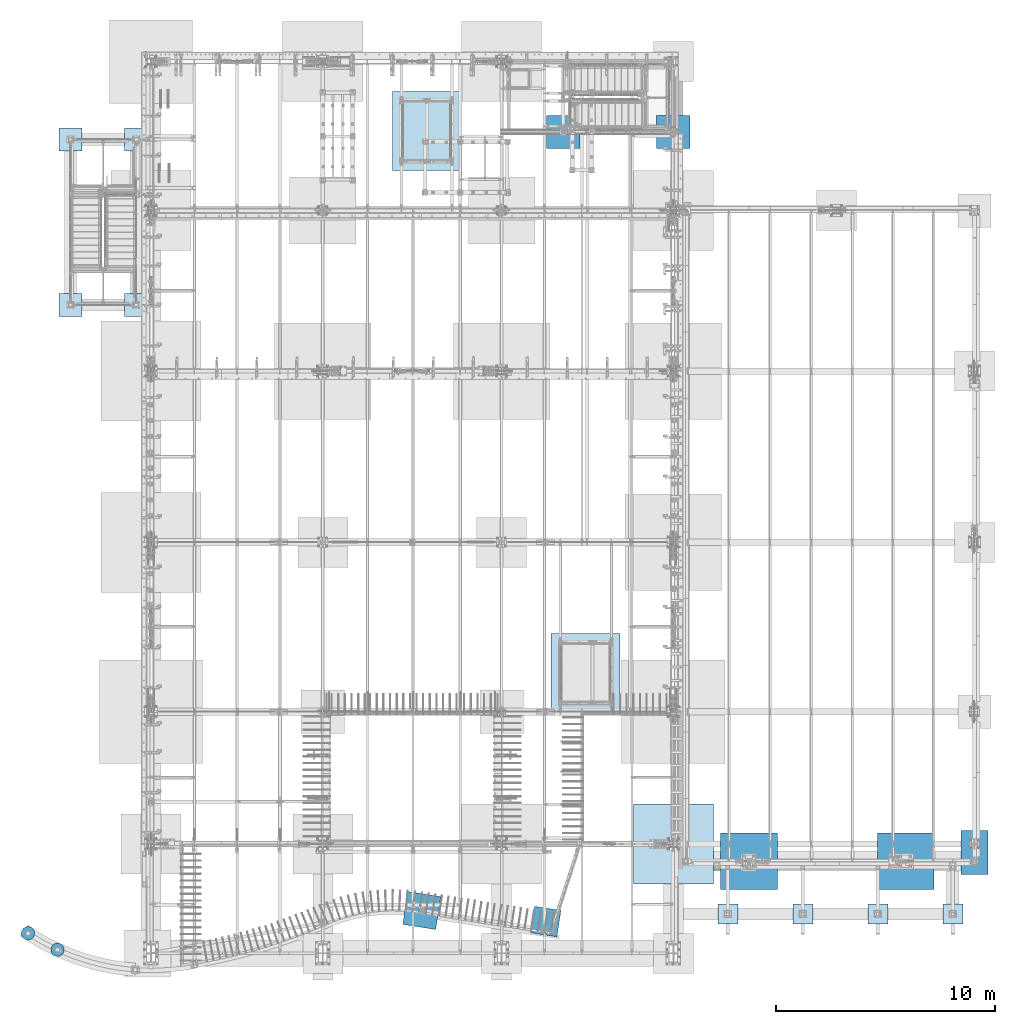
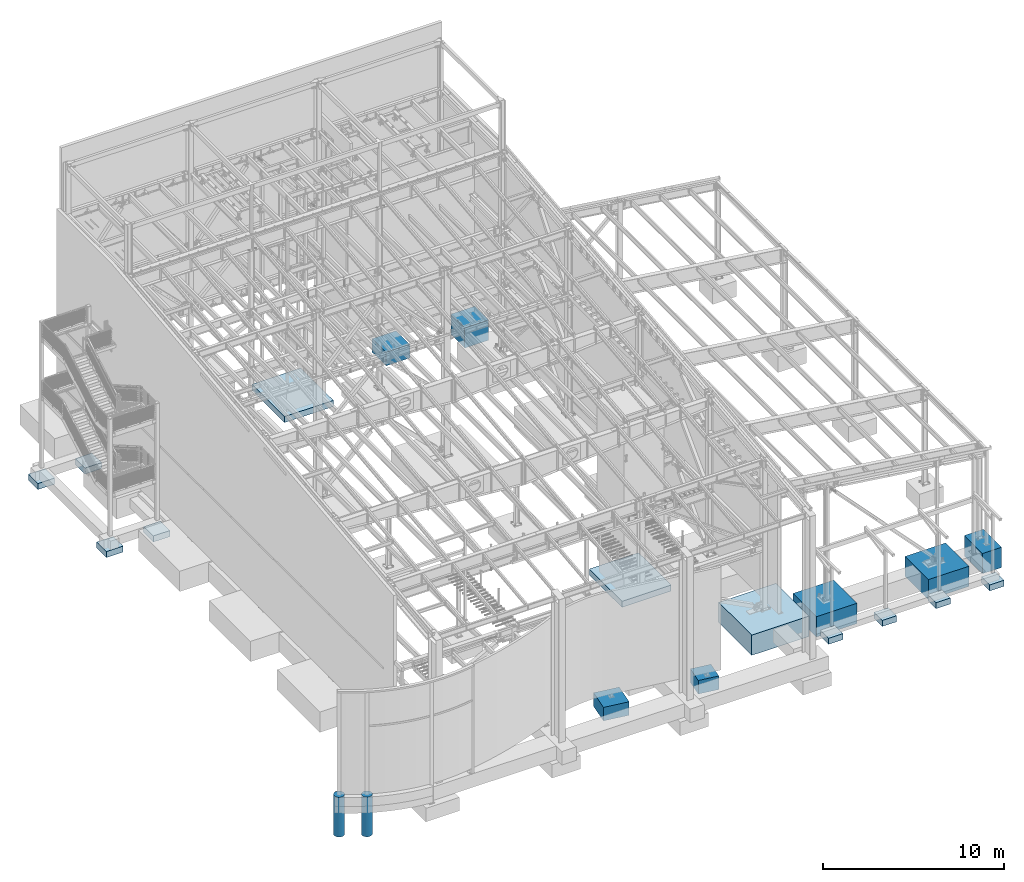
# One storey, part 350 of 1179: 20 footings, 20 elements without a shape of their own.
"""IFC2X3 building model written with IfcOpenShell, lengths in millimetres."""

from ifc_helpers import new_model, si_unit, frame, origin_with_axes, place, context, subcontext, project, spatial, faceted_brep, material, element, aggregate, save


model = new_model("IFC2X3")

# Units and contexts
model_context = context("Model", 3, precision=1e-05, world=origin_with_axes())
body_context = subcontext(model_context, "Body", "Model", "MODEL_VIEW")
ifc_project = project(units=[si_unit("LENGTHUNIT", "METRE", prefix="MILLI"), si_unit("AREAUNIT", "SQUARE_METRE"), si_unit("VOLUMEUNIT", "CUBIC_METRE"), si_unit("MASSUNIT", "GRAM", prefix="KILO"), si_unit("TIMEUNIT", "SECOND"), si_unit("PLANEANGLEUNIT", "RADIAN"), si_unit("SOLIDANGLEUNIT", "STERADIAN"), si_unit("THERMODYNAMICTEMPERATUREUNIT", "DEGREE_CELSIUS"), si_unit("LUMINOUSINTENSITYUNIT", "LUMEN")], contexts=[model_context])

# Site, building, storey
site_placement = place(None, origin_with_axes())
site = spatial("IfcSite", under=ifc_project, at=site_placement, CompositionType="ELEMENT")
building_placement = place(site_placement, origin_with_axes())
building = spatial("IfcBuilding", under=site, at=building_placement, Name="Undefined", CompositionType="ELEMENT")
storey_placement = place(building_placement, origin_with_axes())
storey = spatial("IfcBuildingStorey", under=building, at=storey_placement, Name="Undefined", CompositionType="ELEMENT", Elevation=0.0)

# Assembly, footing
assembly_1_placement = place(storey_placement, origin_with_axes())
assembly_1 = element("IfcElementAssembly", 1, at=assembly_1_placement, inside=storey, Name="PAD FOOTING", AssemblyPlace="NOTDEFINED", PredefinedType="REINFORCEMENT_UNIT")
ifc_material = material(Name="CONCRETE/3000")
footing_1_placement = place(assembly_1_placement, frame((-254.0, 37642.8, -1651.0), z_axis=(1.0, 0.0, 0.0), x_axis=(0.0, 0.0, 1.0)))
footing_1 = element("IfcFooting", 2, at=footing_1_placement, material=ifc_material, Name="PAD FOOTING", PredefinedType="NOTDEFINED", context=body_context, shape_type="Brep", body=[
    faceted_brep([(0.0, 533.400000000001, -533.4), (0.0, 533.400000000001, 533.4), (406.4, 533.400000000001, 533.4), (406.4, 533.400000000001, -533.4), (0.0, -533.400000000001, 533.4), (406.4, -533.400000000001, 533.4), (0.0, -533.400000000001, -533.4), (406.4, -533.400000000001, -533.4)], [[[0, 1, 2, 3]], [[1, 4, 5, 2]], [[4, 6, 7, 5]], [[6, 0, 3, 7]], [[5, 7, 3, 2]], [[6, 4, 1, 0]]]),
])
aggregate(assembly_1, [footing_1])

assembly_2_placement = place(storey_placement, origin_with_axes())
assembly_2 = element("IfcElementAssembly", 3, at=assembly_2_placement, inside=storey, Name="PAD FOOTING", AssemblyPlace="NOTDEFINED", PredefinedType="REINFORCEMENT_UNIT")
footing_2_placement = place(assembly_2_placement, frame((-254.0, 30073.6, -1651.0), z_axis=(1.0, 0.0, 0.0), x_axis=(0.0, 0.0, 1.0)))
footing_2 = element("IfcFooting", 4, at=footing_2_placement, material=ifc_material, Name="PAD FOOTING", PredefinedType="NOTDEFINED", context=body_context, shape_type="Brep", body=[
    faceted_brep([(0.0, 533.400000000001, -533.4), (0.0, 533.400000000001, 533.4), (406.4, 533.400000000001, 533.4), (406.4, 533.400000000001, -533.4), (0.0, -533.400000000001, 533.4), (406.4, -533.400000000001, 533.4), (0.0, -533.400000000001, -533.4), (406.4, -533.400000000001, -533.4)], [[[0, 1, 2, 3]], [[1, 4, 5, 2]], [[4, 6, 7, 5]], [[6, 0, 3, 7]], [[5, 7, 3, 2]], [[6, 4, 1, 0]]]),
])
aggregate(assembly_2, [footing_2])

assembly_3_placement = place(storey_placement, origin_with_axes())
assembly_3 = element("IfcElementAssembly", 5, at=assembly_3_placement, inside=storey, Name="PAD FOOTING", AssemblyPlace="NOTDEFINED", PredefinedType="REINFORCEMENT_UNIT")
footing_3_placement = place(assembly_3_placement, frame((-3251.2, 30073.6, -1651.0), z_axis=(1.0, 0.0, 0.0), x_axis=(0.0, 0.0, 1.0)))
footing_3 = element("IfcFooting", 6, at=footing_3_placement, material=ifc_material, Name="PAD FOOTING", PredefinedType="NOTDEFINED", context=body_context, shape_type="Brep", body=[
    faceted_brep([(0.0, 533.400000000001, -533.4), (0.0, 533.400000000001, 533.4), (406.4, 533.400000000001, 533.4), (406.4, 533.400000000001, -533.4), (0.0, -533.400000000001, 533.4), (406.4, -533.400000000001, 533.4), (0.0, -533.400000000001, -533.4), (406.4, -533.400000000001, -533.4)], [[[0, 1, 2, 3]], [[1, 4, 5, 2]], [[4, 6, 7, 5]], [[6, 0, 3, 7]], [[5, 7, 3, 2]], [[6, 4, 1, 0]]]),
])
aggregate(assembly_3, [footing_3])

assembly_4_placement = place(storey_placement, origin_with_axes())
assembly_4 = element("IfcElementAssembly", 7, at=assembly_4_placement, inside=storey, Name="PAD FOOTING", AssemblyPlace="NOTDEFINED", PredefinedType="REINFORCEMENT_UNIT")
footing_4_placement = place(assembly_4_placement, frame((-3251.2, 37642.8, -1651.0), z_axis=(1.0, 0.0, 0.0), x_axis=(0.0, 0.0, 1.0)))
footing_4 = element("IfcFooting", 8, at=footing_4_placement, material=ifc_material, Name="PAD FOOTING", PredefinedType="NOTDEFINED", context=body_context, shape_type="Brep", body=[
    faceted_brep([(0.0, 533.400000000001, -533.4), (0.0, 533.400000000001, 533.4), (406.4, 533.400000000001, 533.4), (406.4, 533.400000000001, -533.4), (0.0, -533.400000000001, 533.4), (406.4, -533.400000000001, 533.4), (0.0, -533.400000000001, -533.4), (406.4, -533.400000000001, -533.4)], [[[0, 1, 2, 3]], [[1, 4, 5, 2]], [[4, 6, 7, 5]], [[6, 0, 3, 7]], [[5, 7, 3, 2]], [[6, 4, 1, 0]]]),
])
aggregate(assembly_4, [footing_4])

assembly_5_placement = place(storey_placement, origin_with_axes())
assembly_5 = element("IfcElementAssembly", 9, at=assembly_5_placement, inside=storey, Name="PAD FOOTING", AssemblyPlace="NOTDEFINED", PredefinedType="REINFORCEMENT_UNIT")
footing_5_placement = place(assembly_5_placement, frame((18475.5679045266, 1891.26503542878, -1346.2), z_axis=(0.988012031439376, -0.154376895068652, 0.0), x_axis=(0.0, 0.0, 1.0)))
footing_5 = element("IfcFooting", 10, at=footing_5_placement, material=ifc_material, Name="PAD FOOTING", PredefinedType="NOTDEFINED", context=body_context, shape_type="Brep", body=[
    faceted_brep([(0.0, 609.600000000165, -609.600000001028), (0.0, 609.59999999992, 609.600000000977), (914.4, 609.59999999992, 609.600000000977), (914.4, 609.600000000165, -609.600000001028), (0.0, -609.600000000166, 609.600000001032), (914.4, -609.600000000166, 609.600000001032), (0.0, -609.599999999921, -609.600000000974), (914.4, -609.599999999921, -609.600000000974)], [[[0, 1, 2, 3]], [[1, 4, 5, 2]], [[4, 6, 7, 5]], [[6, 0, 3, 7]], [[5, 7, 3, 2]], [[6, 4, 1, 0]]]),
])
aggregate(assembly_5, [footing_5])

assembly_6_placement = place(storey_placement, origin_with_axes())
assembly_6 = element("IfcElementAssembly", 11, at=assembly_6_placement, inside=storey, Name="PAD FOOTING", AssemblyPlace="NOTDEFINED", PredefinedType="REINFORCEMENT_UNIT")
footing_6_placement = place(assembly_6_placement, frame((12807.7286542525, 2395.53749981878, -1346.2), z_axis=(0.988012031439376, -0.154376895068652, 0.0), x_axis=(0.0, 0.0, 1.0)))
footing_6 = element("IfcFooting", 12, at=footing_6_placement, material=ifc_material, Name="PAD FOOTING", PredefinedType="NOTDEFINED", context=body_context, shape_type="Brep", body=[
    faceted_brep([(0.0, 761.999999999822, -761.999999999945), (0.0, 761.999999999945, 761.99999999982), (914.4, 761.999999999945, 761.99999999982), (914.4, 761.999999999822, -761.999999999945), (0.0, -761.999999999821, 761.999999999942), (914.4, -761.999999999821, 761.999999999942), (0.0, -761.999999999944, -761.999999999822), (914.4, -761.999999999944, -761.999999999822)], [[[0, 1, 2, 3]], [[1, 4, 5, 2]], [[4, 6, 7, 5]], [[6, 0, 3, 7]], [[5, 7, 3, 2]], [[6, 4, 1, 0]]]),
])
aggregate(assembly_6, [footing_6])

assembly_7_placement = place(storey_placement, origin_with_axes())
assembly_7 = element("IfcElementAssembly", 13, at=assembly_7_placement, inside=storey, Name="PAD FOOTING", AssemblyPlace="NOTDEFINED", PredefinedType="REINFORCEMENT_UNIT")
footing_7_placement = place(assembly_7_placement, frame((-3844.53850771184, 604.295940921921, -2736.85), z_axis=(0.838301827710955, -0.545206424812013, 4.1895464528352e-07), x_axis=(0.0, 0.0, 1.0)))
footing_7 = element("IfcFooting", 14, at=footing_7_placement, material=ifc_material, Name="PAD FOOTING", PredefinedType="NOTDEFINED", context=body_context, shape_type="Brep", body=[
    faceted_brep([(4.86579665448517e-11, -304.799999999989, 9.09494701772928e-13), (4.86579665448517e-11, -301.047406213389, -47.6812249442592), (2686.04924693073, -301.047406213455, -47.6812249444038), (2686.04924693073, -304.800000000056, -1.43700162880123e-10), (4.68389771413058e-11, -289.882026166756, -94.1883798854783), (2686.04924693073, -289.882026166823, -94.1883798856234), (4.4110493035987e-11, -271.578788572611, -138.376304320606), (2686.04924693073, -271.578788572677, -138.376304320751), (4.04725142288953e-11, -246.588379885482, -179.156944898736), (2686.04924693073, -246.588379885549, -179.156944898882), (3.54702933691442e-11, -215.526146905661, -215.526146905649), (2686.04924693072, -215.526146905727, -215.526146905794), (2.95585778076202e-11, -179.156944898749, -246.588379885472), (2686.04924693071, -179.156944898816, -246.588379885617), (2.36468622460961e-11, -138.37630432062, -271.578788572602), (2686.04924693071, -138.376304320687, -271.578788572746), (1.63709046319127e-11, -94.1883798854922, -289.882026166749), (2686.0492469307, -94.1883798855592, -289.882026166894), (9.09494701772928e-12, -47.681224944273, -301.047406213384), (2686.04924693069, -47.6812249443396, -301.047406213529), (1.36424205265939e-12, -1.2732925824821e-11, -304.799999999986), (2686.04924693069, -7.91260390542448e-11, -304.800000000131), (-6.3664629124105e-12, 47.6812249442478, -301.047406213384), (2686.04924693068, 47.6812249441812, -301.047406213529), (-1.36424205265939e-11, 94.1883798854687, -289.88202616675), (2686.04924693067, 94.1883798854017, -289.882026166894), (-2.09183781407773e-11, 138.376304320598, -271.578788572603), (2686.04924693066, 138.376304320531, -271.578788572747), (-2.77395884040743e-11, 179.156944898729, -246.588379885473), (2686.04924693066, 179.156944898662, -246.588379885618), (-3.31965566147119e-11, 215.526146905643, -215.52614690565), (2686.04924693065, 215.526146905576, -215.526146905796), (-3.8198777474463e-11, 246.588379885467, -179.156944898738), (2686.04924693065, 246.588379885401, -179.156944898884), (-4.22915036324412e-11, 271.578788572599, -138.376304320609), (2686.04924693064, 271.578788572532, -138.376304320753), (-4.54747350886464e-11, 289.882026166748, -94.1883798854801), (2686.04924693064, 289.882026166681, -94.1883798856256), (-4.72937244921923e-11, 301.047406213385, -47.6812249442614), (2686.04924693064, 301.047406213318, -47.6812249444065), (-4.82032191939652e-11, 304.799999999989, -4.54747350886464e-13), (2686.04924693064, 304.799999999922, -1.46428646985441e-10), (-4.77484718430787e-11, 301.047406213389, 47.6812249442592), (2686.04924693064, 301.047406213322, 47.6812249441141), (-4.63842297904193e-11, 289.882026166755, 94.1883798854788), (2686.04924693064, 289.882026166689, 94.1883798853337), (-4.36557456851006e-11, 271.57878857261, 138.376304320606), (2686.04924693064, 271.578788572543, 138.376304320461), (-3.95630195271224e-11, 246.588379885482, 179.156944898737), (2686.04924693065, 246.588379885415, 179.156944898592), (-3.50155460182577e-11, 215.52614690566, 215.526146905649), (2686.04924693065, 215.526146905594, 215.526146905504), (-2.91038304567337e-11, 179.156944898749, 246.588379885472), (2686.04924693066, 179.156944898682, 246.588379885327), (-2.27373675443232e-11, 138.376304320619, 271.578788572602), (2686.04924693066, 138.376304320553, 271.578788572456), (-1.59161572810262e-11, 94.1883798854922, 289.882026166749), (2686.04924693067, 94.1883798854255, 289.882026166604), (-8.18545231595635e-12, 47.681224944273, 301.047406213384), (2686.04924693068, 47.6812249442062, 301.047406213239), (-4.54747350886464e-13, 1.25055521493778e-11, 304.799999999986), (2686.04924693068, -5.43423084309325e-11, 304.799999999841), (6.82121026329696e-12, -47.6812249442487, 301.047406213384), (2686.04924693069, -47.6812249443153, 301.047406213239), (1.45519152283669e-11, -94.1883798854687, 289.88202616675), (2686.0492469307, -94.1883798855356, 289.882026166605), (2.13731254916638e-11, -138.376304320598, 271.578788572602), (2686.04924693071, -138.376304320665, 271.578788572457), (2.81943357549608e-11, -179.156944898729, 246.588379885474), (2686.04924693071, -179.156944898796, 246.588379885328), (3.41060513164848e-11, -215.526146905643, 215.526146905651), (2686.04924693072, -215.52614690571, 215.526146905506), (3.91082721762359e-11, -246.588379885468, 179.156944898738), (2686.04924693072, -246.588379885534, 179.156944898594), (4.32009983342141e-11, -271.578788572599, 138.376304320609), (2686.04924693073, -271.578788572666, 138.376304320464), (4.59294824395329e-11, -289.882026166748, 94.1883798854806), (2686.04924693073, -289.882026166815, 94.1883798853355), (4.82032191939652e-11, -301.047406213385, 47.6812249442614), (2686.04924693073, -301.047406213452, 47.6812249441168)], [[[0, 1, 2, 3]], [[1, 4, 5, 2]], [[4, 6, 7, 5]], [[6, 8, 9, 7]], [[8, 10, 11, 9]], [[10, 12, 13, 11]], [[12, 14, 15, 13]], [[14, 16, 17, 15]], [[16, 18, 19, 17]], [[18, 20, 21, 19]], [[20, 22, 23, 21]], [[22, 24, 25, 23]], [[24, 26, 27, 25]], [[26, 28, 29, 27]], [[28, 30, 31, 29]], [[30, 32, 33, 31]], [[32, 34, 35, 33]], [[34, 36, 37, 35]], [[36, 38, 39, 37]], [[38, 40, 41, 39]], [[40, 42, 43, 41]], [[42, 44, 45, 43]], [[44, 46, 47, 45]], [[46, 48, 49, 47]], [[48, 50, 51, 49]], [[50, 52, 53, 51]], [[52, 54, 55, 53]], [[54, 56, 57, 55]], [[56, 58, 59, 57]], [[58, 60, 61, 59]], [[60, 62, 63, 61]], [[62, 64, 65, 63]], [[64, 66, 67, 65]], [[66, 68, 69, 67]], [[68, 70, 71, 69]], [[70, 72, 73, 71]], [[72, 74, 75, 73]], [[74, 76, 77, 75]], [[76, 78, 79, 77]], [[78, 0, 3, 79]], [[5, 7, 9, 11, 13, 15, 17, 19, 21, 23, 25, 27, 29, 31, 33, 35, 37, 39, 41, 43, 45, 47, 49, 51, 53, 55, 57, 59, 61, 63, 65, 67, 69, 71, 73, 75, 77, 79, 3, 2]], [[78, 76, 74, 72, 70, 68, 66, 64, 62, 60, 58, 56, 54, 52, 50, 48, 46, 44, 42, 40, 38, 36, 34, 32, 30, 28, 26, 24, 22, 20, 18, 16, 14, 12, 10, 8, 6, 4, 1, 0]]]),
])
aggregate(assembly_7, [footing_7])

assembly_8_placement = place(storey_placement, origin_with_axes())
assembly_8 = element("IfcElementAssembly", 15, at=assembly_8_placement, inside=storey, Name="PAD FOOTING", AssemblyPlace="NOTDEFINED", PredefinedType="REINFORCEMENT_UNIT")
footing_8_placement = place(assembly_8_placement, frame((-5190.66030825409, 1354.32481527557, -2736.85), z_axis=(0.838327208957388, -0.545167396972289, 4.18957444708212e-07), x_axis=(0.0, 0.0, 1.0)))
footing_8 = element("IfcFooting", 16, at=footing_8_placement, material=ifc_material, Name="PAD FOOTING", PredefinedType="NOTDEFINED", context=body_context, shape_type="Brep", body=[
    faceted_brep([(4.86579665448517e-11, -304.799999999989, 9.09494701772928e-13), (4.86579665448517e-11, -301.047406213389, -47.6812249442592), (2686.04924693073, -301.047406213455, -47.6812249444038), (2686.04924693073, -304.800000000056, -1.43700162880123e-10), (4.68389771413058e-11, -289.882026166756, -94.1883798854783), (2686.04924693073, -289.882026166823, -94.1883798856234), (4.4110493035987e-11, -271.578788572611, -138.376304320606), (2686.04924693073, -271.578788572677, -138.376304320751), (4.04725142288953e-11, -246.588379885482, -179.156944898736), (2686.04924693073, -246.588379885549, -179.156944898882), (3.54702933691442e-11, -215.526146905661, -215.526146905649), (2686.04924693072, -215.526146905727, -215.526146905794), (2.95585778076202e-11, -179.156944898749, -246.588379885472), (2686.04924693071, -179.156944898816, -246.588379885617), (2.36468622460961e-11, -138.37630432062, -271.578788572602), (2686.04924693071, -138.376304320687, -271.578788572746), (1.63709046319127e-11, -94.1883798854922, -289.882026166749), (2686.0492469307, -94.1883798855592, -289.882026166894), (9.09494701772928e-12, -47.681224944273, -301.047406213384), (2686.04924693069, -47.6812249443396, -301.047406213529), (1.36424205265939e-12, -1.2732925824821e-11, -304.799999999986), (2686.04924693069, -7.91260390542448e-11, -304.800000000131), (-6.3664629124105e-12, 47.6812249442478, -301.047406213384), (2686.04924693068, 47.6812249441812, -301.047406213529), (-1.36424205265939e-11, 94.1883798854687, -289.88202616675), (2686.04924693067, 94.1883798854017, -289.882026166894), (-2.09183781407773e-11, 138.376304320598, -271.578788572603), (2686.04924693066, 138.376304320531, -271.578788572747), (-2.77395884040743e-11, 179.156944898729, -246.588379885473), (2686.04924693066, 179.156944898662, -246.588379885618), (-3.31965566147119e-11, 215.526146905643, -215.52614690565), (2686.04924693065, 215.526146905576, -215.526146905796), (-3.8198777474463e-11, 246.588379885467, -179.156944898738), (2686.04924693065, 246.588379885401, -179.156944898884), (-4.22915036324412e-11, 271.578788572599, -138.376304320609), (2686.04924693064, 271.578788572532, -138.376304320753), (-4.54747350886464e-11, 289.882026166748, -94.1883798854801), (2686.04924693064, 289.882026166681, -94.1883798856256), (-4.72937244921923e-11, 301.047406213385, -47.6812249442614), (2686.04924693064, 301.047406213318, -47.6812249444065), (-4.82032191939652e-11, 304.799999999989, -4.54747350886464e-13), (2686.04924693064, 304.799999999922, -1.46428646985441e-10), (-4.77484718430787e-11, 301.047406213389, 47.6812249442592), (2686.04924693064, 301.047406213322, 47.6812249441141), (-4.63842297904193e-11, 289.882026166755, 94.1883798854788), (2686.04924693064, 289.882026166689, 94.1883798853337), (-4.36557456851006e-11, 271.57878857261, 138.376304320606), (2686.04924693064, 271.578788572543, 138.376304320461), (-3.95630195271224e-11, 246.588379885482, 179.156944898737), (2686.04924693065, 246.588379885415, 179.156944898592), (-3.50155460182577e-11, 215.52614690566, 215.526146905649), (2686.04924693065, 215.526146905594, 215.526146905504), (-2.91038304567337e-11, 179.156944898749, 246.588379885472), (2686.04924693066, 179.156944898682, 246.588379885327), (-2.27373675443232e-11, 138.376304320619, 271.578788572602), (2686.04924693066, 138.376304320553, 271.578788572456), (-1.59161572810262e-11, 94.1883798854922, 289.882026166749), (2686.04924693067, 94.1883798854255, 289.882026166604), (-8.18545231595635e-12, 47.681224944273, 301.047406213384), (2686.04924693068, 47.6812249442062, 301.047406213239), (-4.54747350886464e-13, 1.25055521493778e-11, 304.799999999986), (2686.04924693068, -5.43423084309325e-11, 304.799999999841), (6.82121026329696e-12, -47.6812249442487, 301.047406213384), (2686.04924693069, -47.6812249443153, 301.047406213239), (1.45519152283669e-11, -94.1883798854687, 289.88202616675), (2686.0492469307, -94.1883798855356, 289.882026166605), (2.13731254916638e-11, -138.376304320598, 271.578788572602), (2686.04924693071, -138.376304320665, 271.578788572457), (2.81943357549608e-11, -179.156944898729, 246.588379885474), (2686.04924693071, -179.156944898796, 246.588379885328), (3.41060513164848e-11, -215.526146905643, 215.526146905651), (2686.04924693072, -215.52614690571, 215.526146905506), (3.91082721762359e-11, -246.588379885468, 179.156944898738), (2686.04924693072, -246.588379885534, 179.156944898594), (4.32009983342141e-11, -271.578788572599, 138.376304320609), (2686.04924693073, -271.578788572666, 138.376304320464), (4.59294824395329e-11, -289.882026166748, 94.1883798854806), (2686.04924693073, -289.882026166815, 94.1883798853355), (4.82032191939652e-11, -301.047406213385, 47.6812249442614), (2686.04924693073, -301.047406213452, 47.6812249441168)], [[[0, 1, 2, 3]], [[1, 4, 5, 2]], [[4, 6, 7, 5]], [[6, 8, 9, 7]], [[8, 10, 11, 9]], [[10, 12, 13, 11]], [[12, 14, 15, 13]], [[14, 16, 17, 15]], [[16, 18, 19, 17]], [[18, 20, 21, 19]], [[20, 22, 23, 21]], [[22, 24, 25, 23]], [[24, 26, 27, 25]], [[26, 28, 29, 27]], [[28, 30, 31, 29]], [[30, 32, 33, 31]], [[32, 34, 35, 33]], [[34, 36, 37, 35]], [[36, 38, 39, 37]], [[38, 40, 41, 39]], [[40, 42, 43, 41]], [[42, 44, 45, 43]], [[44, 46, 47, 45]], [[46, 48, 49, 47]], [[48, 50, 51, 49]], [[50, 52, 53, 51]], [[52, 54, 55, 53]], [[54, 56, 57, 55]], [[56, 58, 59, 57]], [[58, 60, 61, 59]], [[60, 62, 63, 61]], [[62, 64, 65, 63]], [[64, 66, 67, 65]], [[66, 68, 69, 67]], [[68, 70, 71, 69]], [[70, 72, 73, 71]], [[72, 74, 75, 73]], [[74, 76, 77, 75]], [[76, 78, 79, 77]], [[78, 0, 3, 79]], [[5, 7, 9, 11, 13, 15, 17, 19, 21, 23, 25, 27, 29, 31, 33, 35, 37, 39, 41, 43, 45, 47, 49, 51, 53, 55, 57, 59, 61, 63, 65, 67, 69, 71, 73, 75, 77, 79, 3, 2]], [[78, 76, 74, 72, 70, 68, 66, 64, 62, 60, 58, 56, 54, 52, 50, 48, 46, 44, 42, 40, 38, 36, 34, 32, 30, 28, 26, 24, 22, 20, 18, 16, 14, 12, 10, 8, 6, 4, 1, 0]]]),
])
aggregate(assembly_8, [footing_8])

assembly_9_placement = place(storey_placement, origin_with_axes())
assembly_9 = element("IfcElementAssembly", 17, at=assembly_9_placement, inside=storey, Name="PAD FOOTING", AssemblyPlace="NOTDEFINED", PredefinedType="REINFORCEMENT_UNIT")
footing_9_placement = place(assembly_9_placement, frame((20294.6000000429, 13265.1500491377, -1930.4), z_axis=(1.0, 0.0, 0.0), x_axis=(0.0, 0.0, 1.0)))
footing_9 = element("IfcFooting", 18, at=footing_9_placement, material=ifc_material, Name="PAD FOOTING", PredefinedType="NOTDEFINED", context=body_context, shape_type="Brep", body=[
    faceted_brep([(0.0, 1803.4, -1574.8), (0.0, 1803.4, 1574.8), (406.4, 1803.4, 1574.8), (406.4, 1803.4, -1574.8), (0.0, -1803.4, 1574.8), (406.4, -1803.4, 1574.8), (0.0, -1803.4, -1574.8), (406.4, -1803.4, -1574.8)], [[[0, 1, 2, 3]], [[1, 4, 5, 2]], [[4, 6, 7, 5]], [[6, 0, 3, 7]], [[5, 7, 3, 2]], [[6, 4, 1, 0]]]),
])
aggregate(assembly_9, [footing_9])

assembly_10_placement = place(storey_placement, origin_with_axes())
assembly_10 = element("IfcElementAssembly", 19, at=assembly_10_placement, inside=storey, Name="PAD FOOTING", AssemblyPlace="NOTDEFINED", PredefinedType="REINFORCEMENT_UNIT")
footing_10_placement = place(assembly_10_placement, frame((13025.6116824241, 38036.5000488281, -1930.4), z_axis=(1.0, 0.0, 0.0), x_axis=(0.0, 0.0, 1.0)))
footing_10 = element("IfcFooting", 20, at=footing_10_placement, material=ifc_material, Name="PAD FOOTING", PredefinedType="NOTDEFINED", context=body_context, shape_type="Brep", body=[
    faceted_brep([(0.0, 1803.4, -1562.1), (0.0, 1803.4, 1562.1), (406.4, 1803.4, 1562.1), (406.4, 1803.4, -1562.1), (0.0, -1803.4, 1562.1), (406.4, -1803.4, 1562.1), (0.0, -1803.4, -1562.1), (406.4, -1803.4, -1562.1)], [[[0, 1, 2, 3]], [[1, 4, 5, 2]], [[4, 6, 7, 5]], [[6, 0, 3, 7]], [[5, 7, 3, 2]], [[6, 4, 1, 0]]]),
])
aggregate(assembly_10, [footing_10])

assembly_11_placement = place(storey_placement, origin_with_axes())
assembly_11 = element("IfcElementAssembly", 21, at=assembly_11_placement, inside=storey, Name="PAD FOOTING", AssemblyPlace="NOTDEFINED", PredefinedType="REINFORCEMENT_UNIT")
footing_11_placement = place(assembly_11_placement, frame((24307.8, 37985.7, -1727.2), z_axis=(1.0, 0.0, 0.0), x_axis=(0.0, 0.0, 1.0)))
footing_11 = element("IfcFooting", 22, at=footing_11_placement, material=ifc_material, Name="PAD FOOTING", PredefinedType="NOTDEFINED", context=body_context, shape_type="Brep", body=[
    faceted_brep([(0.0, 761.999999999822, -761.999999999945), (0.0, 761.999999999945, 761.99999999982), (1371.6, 762.0, 762.0), (1371.6, 762.0, -762.0), (0.0, -761.999999999821, 761.999999999942), (1371.6, -762.0, 762.0), (0.0, -761.999999999944, -761.999999999822), (1371.6, -762.0, -762.0)], [[[0, 1, 2, 3]], [[1, 4, 5, 2]], [[4, 6, 7, 5]], [[6, 0, 3, 7]], [[5, 7, 3, 2]], [[6, 4, 1, 0]]]),
])
aggregate(assembly_11, [footing_11])

assembly_12_placement = place(storey_placement, origin_with_axes())
assembly_12 = element("IfcElementAssembly", 23, at=assembly_12_placement, inside=storey, Name="PAD FOOTING", AssemblyPlace="NOTDEFINED", PredefinedType="REINFORCEMENT_UNIT")
footing_12_placement = place(assembly_12_placement, frame((19278.6000183103, 37985.7, -1168.4), z_axis=(1.0, 0.0, 0.0), x_axis=(0.0, 0.0, 1.0)))
footing_12 = element("IfcFooting", 24, at=footing_12_placement, material=ifc_material, Name="PAD FOOTING", PredefinedType="NOTDEFINED", context=body_context, shape_type="Brep", body=[
    faceted_brep([(0.0, 761.999999999822, -761.999999999945), (0.0, 761.999999999945, 761.99999999982), (914.4, 761.999999999945, 761.99999999982), (914.4, 761.999999999822, -761.999999999945), (0.0, -761.999999999821, 761.999999999942), (914.4, -761.999999999821, 761.999999999942), (0.0, -761.999999999944, -761.999999999822), (914.4, -761.999999999944, -761.999999999822)], [[[0, 1, 2, 3]], [[1, 4, 5, 2]], [[4, 6, 7, 5]], [[6, 0, 3, 7]], [[5, 7, 3, 2]], [[6, 4, 1, 0]]]),
])
aggregate(assembly_12, [footing_12])

assembly_13_placement = place(storey_placement, origin_with_axes())
assembly_13 = element("IfcElementAssembly", 25, at=assembly_13_placement, inside=storey, Name="PAD FOOTING", AssemblyPlace="NOTDEFINED", PredefinedType="REINFORCEMENT_UNIT")
footing_13_placement = place(assembly_13_placement, frame((24307.8, 5435.6, -1727.2), z_axis=(1.0, 0.0, 0.0), x_axis=(0.0, 0.0, 1.0)))
footing_13 = element("IfcFooting", 26, at=footing_13_placement, material=ifc_material, Name="PAD FOOTING", PredefinedType="NOTDEFINED", context=body_context, shape_type="Brep", body=[
    faceted_brep([(0.0, 1828.8, -1828.8), (0.0, 1828.8, 1828.8), (1371.6, 1828.8, 1828.8), (1371.6, 1828.8, -1828.8), (0.0, -1828.8, 1828.8), (1371.6, -1828.8, 1828.8), (0.0, -1828.8, -1828.8), (1371.6, -1828.8, -1828.8)], [[[0, 1, 2, 3]], [[1, 4, 5, 2]], [[4, 6, 7, 5]], [[6, 0, 3, 7]], [[5, 7, 3, 2]], [[6, 4, 1, 0]]]),
])
aggregate(assembly_13, [footing_13])

assembly_14_placement = place(storey_placement, origin_with_axes())
assembly_14 = element("IfcElementAssembly", 27, at=assembly_14_placement, inside=storey, Name="PAD FOOTING", AssemblyPlace="NOTDEFINED", PredefinedType="REINFORCEMENT_UNIT")
footing_14_placement = place(assembly_14_placement, frame((38074.6, 5041.9, -1727.2), z_axis=(1.0, 0.0, 0.0), x_axis=(0.0, 0.0, 1.0)))
footing_14 = element("IfcFooting", 28, at=footing_14_placement, material=ifc_material, Name="PAD FOOTING", PredefinedType="NOTDEFINED", context=body_context, shape_type="Brep", body=[
    faceted_brep([(0.0, 1003.3, -609.599999999999), (0.0, 1003.3, 609.599999999999), (1371.6, 1003.3, 609.599999999999), (1371.6, 1003.3, -609.599999999999), (0.0, -1003.3, 609.599999999999), (1371.6, -1003.3, 609.599999999999), (0.0, -1003.3, -609.599999999999), (1371.6, -1003.3, -609.599999999999)], [[[0, 1, 2, 3]], [[1, 4, 5, 2]], [[4, 6, 7, 5]], [[6, 0, 3, 7]], [[5, 7, 3, 2]], [[6, 4, 1, 0]]]),
])
aggregate(assembly_14, [footing_14])

assembly_15_placement = place(storey_placement, origin_with_axes())
assembly_15 = element("IfcElementAssembly", 29, at=assembly_15_placement, inside=storey, Name="PAD FOOTING", AssemblyPlace="NOTDEFINED", PredefinedType="REINFORCEMENT_UNIT")
footing_15_placement = place(assembly_15_placement, frame((27762.2, 4648.2, -1727.2), z_axis=(1.0, 0.0, 0.0), x_axis=(0.0, 0.0, 1.0)))
footing_15 = element("IfcFooting", 30, at=footing_15_placement, material=ifc_material, Name="PAD FOOTING", PredefinedType="NOTDEFINED", context=body_context, shape_type="Brep", body=[
    faceted_brep([(0.0, 1295.4, -1295.4), (0.0, 1295.4, 1295.4), (1371.6, 1295.4, 1295.4), (1371.6, 1295.4, -1295.4), (0.0, -1295.4, 1295.4), (1371.6, -1295.4, 1295.4), (0.0, -1295.4, -1295.4), (1371.6, -1295.4, -1295.4)], [[[0, 1, 2, 3]], [[1, 4, 5, 2]], [[4, 6, 7, 5]], [[6, 0, 3, 7]], [[5, 7, 3, 2]], [[6, 4, 1, 0]]]),
])
aggregate(assembly_15, [footing_15])

assembly_16_placement = place(storey_placement, origin_with_axes())
assembly_16 = element("IfcElementAssembly", 31, at=assembly_16_placement, inside=storey, Name="PAD FOOTING", AssemblyPlace="NOTDEFINED", PredefinedType="REINFORCEMENT_UNIT")
footing_16_placement = place(assembly_16_placement, frame((34925.0, 4648.2, -1727.2), z_axis=(1.0, 0.0, 0.0), x_axis=(0.0, 0.0, 1.0)))
footing_16 = element("IfcFooting", 32, at=footing_16_placement, material=ifc_material, Name="PAD FOOTING", PredefinedType="NOTDEFINED", context=body_context, shape_type="Brep", body=[
    faceted_brep([(0.0, 1295.4, -1295.4), (0.0, 1295.4, 1295.4), (1371.6, 1295.4, 1295.4), (1371.6, 1295.4, -1295.4), (0.0, -1295.4, 1295.4), (1371.6, -1295.4, 1295.4), (0.0, -1295.4, -1295.4), (1371.6, -1295.4, -1295.4)], [[[0, 1, 2, 3]], [[1, 4, 5, 2]], [[4, 6, 7, 5]], [[6, 0, 3, 7]], [[5, 7, 3, 2]], [[6, 4, 1, 0]]]),
])
aggregate(assembly_16, [footing_16])

assembly_17_placement = place(storey_placement, origin_with_axes())
assembly_17 = element("IfcElementAssembly", 33, at=assembly_17_placement, inside=storey, Name="PAD FOOTING", AssemblyPlace="NOTDEFINED", PredefinedType="REINFORCEMENT_UNIT")
footing_17_placement = place(assembly_17_placement, frame((26797.0, 2235.2, -1219.2), z_axis=(1.0, 0.0, 0.0), x_axis=(0.0, 0.0, 1.0)))
footing_17 = element("IfcFooting", 34, at=footing_17_placement, material=ifc_material, Name="PAD FOOTING", PredefinedType="NOTDEFINED", context=body_context, shape_type="Brep", body=[
    faceted_brep([(4.84305928694084e-11, 457.2, -457.2), (4.84305928694084e-11, 457.2, 457.2), (406.4, 457.2, 457.200000000001), (406.4, 457.2, -457.200000000001), (-4.82032191939652e-11, -457.2, 457.2), (406.4, -457.2, 457.200000000001), (-4.82032191939652e-11, -457.2, -457.2), (406.4, -457.2, -457.200000000001)], [[[0, 1, 2, 3]], [[1, 4, 5, 2]], [[4, 6, 7, 5]], [[6, 0, 3, 7]], [[5, 7, 3, 2]], [[6, 4, 1, 0]]]),
])
aggregate(assembly_17, [footing_17])

assembly_18_placement = place(storey_placement, origin_with_axes())
assembly_18 = element("IfcElementAssembly", 35, at=assembly_18_placement, inside=storey, Name="PAD FOOTING", AssemblyPlace="NOTDEFINED", PredefinedType="REINFORCEMENT_UNIT")
footing_18_placement = place(assembly_18_placement, frame((30226.0, 2235.2, -1219.2), z_axis=(1.0, 0.0, 0.0), x_axis=(0.0, 0.0, 1.0)))
footing_18 = element("IfcFooting", 36, at=footing_18_placement, material=ifc_material, Name="PAD FOOTING", PredefinedType="NOTDEFINED", context=body_context, shape_type="Brep", body=[
    faceted_brep([(4.84305928694084e-11, 457.2, -457.2), (4.84305928694084e-11, 457.2, 457.2), (406.4, 457.2, 457.200000000001), (406.4, 457.2, -457.200000000001), (-4.82032191939652e-11, -457.2, 457.2), (406.4, -457.2, 457.200000000001), (-4.82032191939652e-11, -457.2, -457.2), (406.4, -457.2, -457.200000000001)], [[[0, 1, 2, 3]], [[1, 4, 5, 2]], [[4, 6, 7, 5]], [[6, 0, 3, 7]], [[5, 7, 3, 2]], [[6, 4, 1, 0]]]),
])
aggregate(assembly_18, [footing_18])

assembly_19_placement = place(storey_placement, origin_with_axes())
assembly_19 = element("IfcElementAssembly", 37, at=assembly_19_placement, inside=storey, Name="PAD FOOTING", AssemblyPlace="NOTDEFINED", PredefinedType="REINFORCEMENT_UNIT")
footing_19_placement = place(assembly_19_placement, frame((33655.0, 2235.2, -1219.2), z_axis=(1.0, 0.0, 0.0), x_axis=(0.0, 0.0, 1.0)))
footing_19 = element("IfcFooting", 38, at=footing_19_placement, material=ifc_material, Name="PAD FOOTING", PredefinedType="NOTDEFINED", context=body_context, shape_type="Brep", body=[
    faceted_brep([(4.84305928694084e-11, 457.2, -457.2), (4.84305928694084e-11, 457.2, 457.2), (406.4, 457.2, 457.200000000001), (406.4, 457.2, -457.200000000001), (-4.82032191939652e-11, -457.2, 457.2), (406.4, -457.2, 457.200000000001), (-4.82032191939652e-11, -457.2, -457.2), (406.4, -457.2, -457.200000000001)], [[[0, 1, 2, 3]], [[1, 4, 5, 2]], [[4, 6, 7, 5]], [[6, 0, 3, 7]], [[5, 7, 3, 2]], [[6, 4, 1, 0]]]),
])
aggregate(assembly_19, [footing_19])

assembly_20_placement = place(storey_placement, origin_with_axes())
assembly_20 = element("IfcElementAssembly", 39, at=assembly_20_placement, inside=storey, Name="PAD FOOTING", AssemblyPlace="NOTDEFINED", PredefinedType="REINFORCEMENT_UNIT")
footing_20_placement = place(assembly_20_placement, frame((37084.0, 2235.2, -1219.2), z_axis=(1.0, 0.0, 0.0), x_axis=(0.0, 0.0, 1.0)))
footing_20 = element("IfcFooting", 40, at=footing_20_placement, material=ifc_material, Name="PAD FOOTING", PredefinedType="NOTDEFINED", context=body_context, shape_type="Brep", body=[
    faceted_brep([(4.84305928694084e-11, 457.2, -457.2), (4.84305928694084e-11, 457.2, 457.2), (406.4, 457.2, 457.200000000001), (406.4, 457.2, -457.200000000001), (-4.82032191939652e-11, -457.2, 457.2), (406.4, -457.2, 457.200000000001), (-4.82032191939652e-11, -457.2, -457.2), (406.4, -457.2, -457.200000000001)], [[[0, 1, 2, 3]], [[1, 4, 5, 2]], [[4, 6, 7, 5]], [[6, 0, 3, 7]], [[5, 7, 3, 2]], [[6, 4, 1, 0]]]),
])
aggregate(assembly_20, [footing_20])

save(model, "model.ifc")
